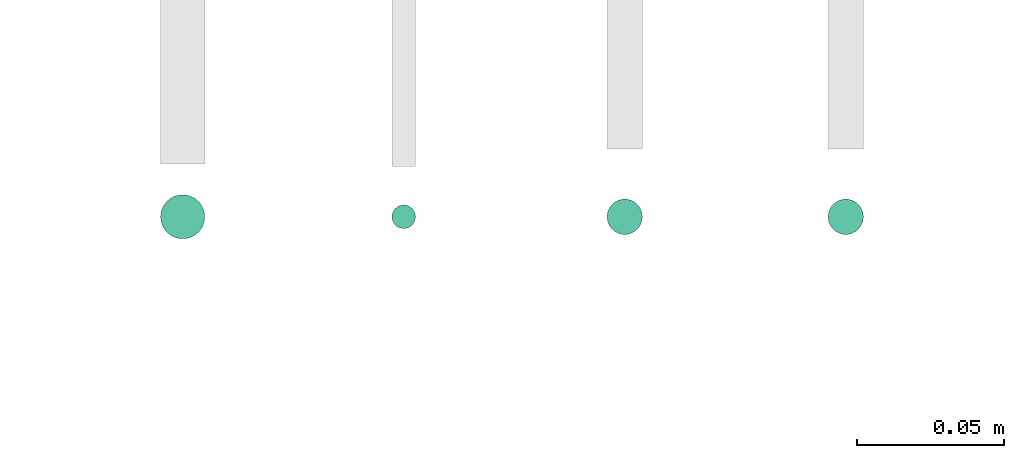
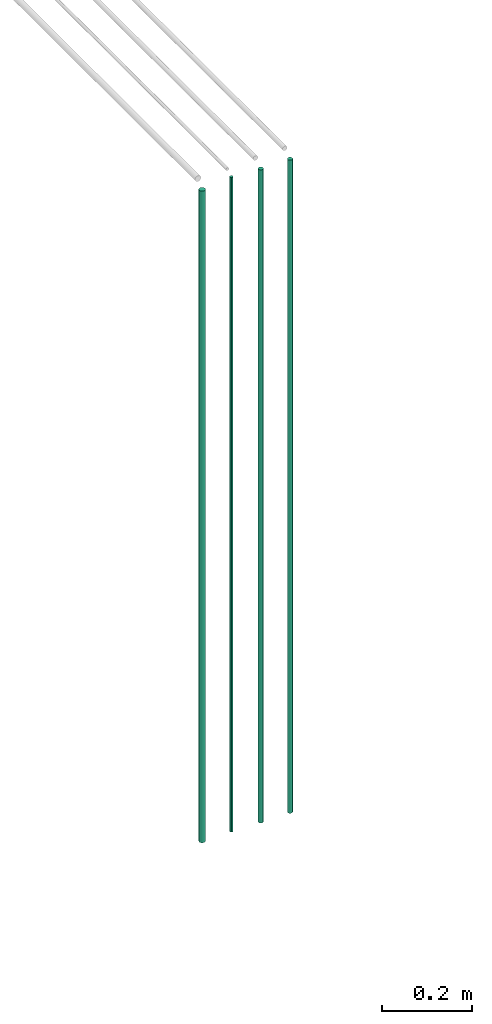
# One storey, part 12 of 65: 4 flow segments.
"""IFC2X3 building model written with IfcOpenShell, lengths in millimetres."""

from ifc_helpers import new_model, entity, si_unit, converted_unit, derived_unit, direction, frame, frame_2d, origin, origin_2d_with_axis, place, context, subcontext, project, spatial, circle, extrude, type_object, element, save


model = new_model("IFC2X3")

# Units and contexts
model_context = context("Model", 3, precision=0.01, world=origin(), true_north=direction((6.12303176911189e-17, 1.0)))
body_context = subcontext(model_context, "Body", "Model", "MODEL_VIEW")
ifc_project = project(units=[si_unit("LENGTHUNIT", "METRE", prefix="MILLI"), si_unit("AREAUNIT", "SQUARE_METRE"), si_unit("VOLUMEUNIT", "CUBIC_METRE"), converted_unit("PLANEANGLEUNIT", "DEGREE", entity("IfcRatioMeasure", 0.0174532925199433), si_unit("PLANEANGLEUNIT", "RADIAN"), dimensions=[0, 0, 0, 0, 0, 0, 0]), si_unit("MASSUNIT", "GRAM", prefix="KILO"), derived_unit("MASSDENSITYUNIT", [(si_unit("MASSUNIT", "GRAM", prefix="KILO"), 1), (si_unit("LENGTHUNIT", "METRE"), -3)]), derived_unit("MOMENTOFINERTIAUNIT", [(si_unit("LENGTHUNIT", "METRE"), 4)]), si_unit("TIMEUNIT", "SECOND"), si_unit("FREQUENCYUNIT", "HERTZ"), si_unit("THERMODYNAMICTEMPERATUREUNIT", "DEGREE_CELSIUS"), derived_unit("THERMALTRANSMITTANCEUNIT", [(si_unit("MASSUNIT", "GRAM", prefix="KILO"), 1), (si_unit("THERMODYNAMICTEMPERATUREUNIT", "KELVIN"), -1), (si_unit("TIMEUNIT", "SECOND"), -3)]), derived_unit("VOLUMETRICFLOWRATEUNIT", [(si_unit("LENGTHUNIT", "METRE"), 3), (si_unit("TIMEUNIT", "SECOND"), -1)]), derived_unit("MASSFLOWRATEUNIT", [(si_unit("MASSUNIT", "GRAM", prefix="KILO"), 1), (si_unit("TIMEUNIT", "SECOND"), -1)]), derived_unit("ROTATIONALFREQUENCYUNIT", [(si_unit("TIMEUNIT", "SECOND"), -1)]), si_unit("ELECTRICCURRENTUNIT", "AMPERE"), si_unit("ELECTRICVOLTAGEUNIT", "VOLT"), si_unit("POWERUNIT", "WATT"), si_unit("FORCEUNIT", "NEWTON", prefix="KILO"), si_unit("ILLUMINANCEUNIT", "LUX"), si_unit("LUMINOUSFLUXUNIT", "LUMEN"), si_unit("LUMINOUSINTENSITYUNIT", "CANDELA"), derived_unit("USERDEFINED", [(si_unit("MASSUNIT", "GRAM", prefix="KILO"), -1), (si_unit("LENGTHUNIT", "METRE"), -2), (si_unit("TIMEUNIT", "SECOND"), 3), (si_unit("LUMINOUSFLUXUNIT", "LUMEN"), 1)]), derived_unit("LINEARVELOCITYUNIT", [(si_unit("LENGTHUNIT", "METRE"), 1), (si_unit("TIMEUNIT", "SECOND"), -1)]), si_unit("PRESSUREUNIT", "PASCAL"), derived_unit("USERDEFINED", [(si_unit("LENGTHUNIT", "METRE"), -2), (si_unit("MASSUNIT", "GRAM", prefix="KILO"), 1), (si_unit("TIMEUNIT", "SECOND"), -2)]), derived_unit("LINEARFORCEUNIT", [(si_unit("MASSUNIT", "GRAM", prefix="KILO"), 1), (si_unit("LENGTHUNIT", "METRE"), 1), (si_unit("TIMEUNIT", "SECOND"), -2), (si_unit("LENGTHUNIT", "METRE"), -1)]), derived_unit("PLANARFORCEUNIT", [(si_unit("MASSUNIT", "GRAM", prefix="KILO"), 1), (si_unit("LENGTHUNIT", "METRE"), 1), (si_unit("TIMEUNIT", "SECOND"), -2), (si_unit("LENGTHUNIT", "METRE"), -2)])], contexts=[model_context])

# Site, building, storey
site_placement = place(None, frame((0.0, -0.00077364408347762, 0.0)))
site = spatial("IfcSite", under=ifc_project, at=site_placement, CompositionType="ELEMENT")
building_placement = place(site_placement, origin())
building = spatial("IfcBuilding", under=site, at=building_placement, CompositionType="ELEMENT")
storey_placement = place(building_placement, frame((0.0, 0.0, 19800.0)))
storey = spatial("IfcBuildingStorey", under=building, at=storey_placement, CompositionType="ELEMENT", Elevation=19800.0)

# Flow segments
pipe_segment_type = type_object("IfcPipeSegmentType", PredefinedType="NOTDEFINED")
flow_segment_1_placement = place(storey_placement, frame((59896.8052438068, 780.904727764047, 1400.0)))
element("IfcFlowSegment", 1, at=flow_segment_1_placement, inside=storey, type_object=pipe_segment_type, context=body_context, shape_type="SweptSolid", body=[
    extrude(circle(Radius=7.5, at=frame_2d((0.0, -1.35358391162299e-13), x_axis=(1.0, 0.0))), frame((9.09527223591419, 9.09527223591595, 0.0), z_axis=(0.0, 0.0, 1.0), x_axis=(-1.0, 0.0, 0.0)), (0.0, 0.0, 1.0), 1761.99999999964),
])
flow_segment_2_placement = place(storey_placement, frame((59975.3052438068, 784.404727764047, 1400.0)))
element("IfcFlowSegment", 2, at=flow_segment_2_placement, inside=storey, type_object=pipe_segment_type, context=body_context, shape_type="SweptSolid", body=[
    extrude(circle(Radius=4.0, at=origin_2d_with_axis()), frame((5.59527223591499, 5.59527223591607, 0.0), z_axis=(0.0, 0.0, 1.0), x_axis=(-1.0, 0.0, 0.0)), (0.0, 0.0, 1.0), 1769.99999999964),
])
for number, where in (
    (3, (60048.3052438068, 782.404727764048, 1400.0)),
    (4, (60123.3052438068, 782.404727764048, 1400.0)),
):
    element("IfcFlowSegment", number, at=place(storey_placement, frame(where)), inside=storey, type_object=pipe_segment_type, context=body_context, shape_type="SweptSolid", body=[
        extrude(circle(Radius=6.0, at=origin_2d_with_axis()), frame((7.59527223591454, 7.59527223591603, 0.0), z_axis=(0.0, 0.0, 1.0), x_axis=(-1.0, 0.0, 0.0)), (0.0, 0.0, 1.0), 1765.99999999964),
    ])

save(model, "model.ifc")
